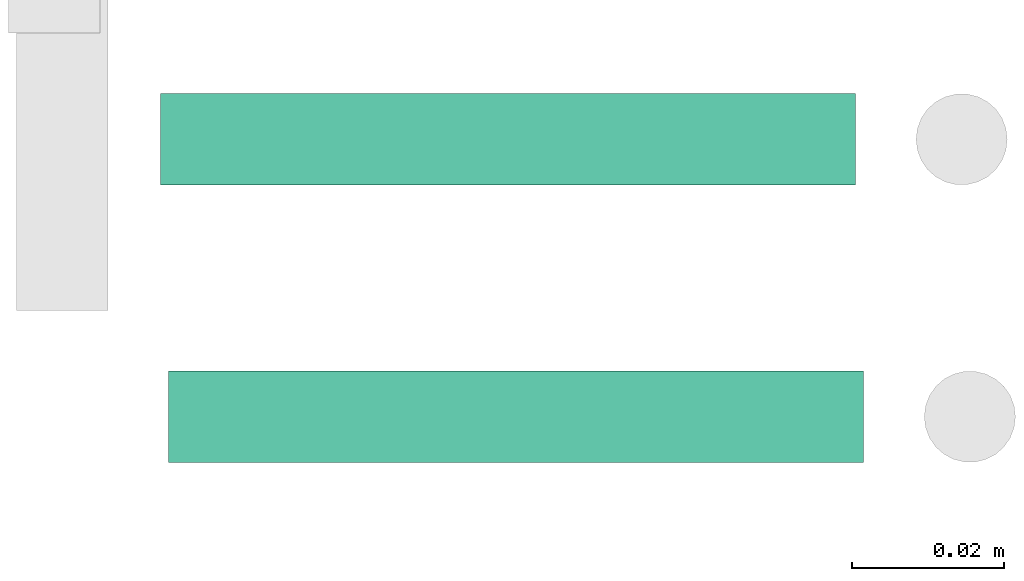
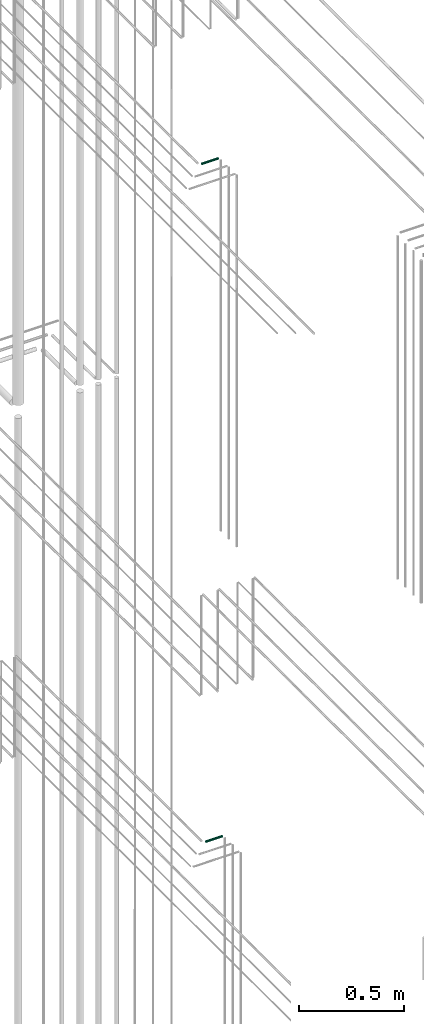
# One storey, part 291 of 331: 2 flow segments.
"""IFC2X3 building model written with IfcOpenShell, lengths in millimetres."""

import ifcopenshell
import ifcopenshell.guid

model = None  # the IFC model being written
_history = None  # IfcOwnerHistory: only IFC2X3 demands one
_inside = {}  # id of a spatial element -> (the spatial element, [elements in it])
_under = {}  # id of a project, library or spatial element -> (it, [spatial elements below it])
_declared = {}  # id of a project -> (the project, [libraries it declares])
_typed = {}  # id of a type object -> (the type object, [elements of that type])
_made_of = {}  # id of a material, layer set ... -> (it, [elements and type objects made of it])


def new_model(schema):
    """Start an empty IFC model of exactly this schema.

    Asked for "IFC4X3", IfcOpenShell would pick the latest addendum, in which some entities
    have other attributes; the version numbers below select the first issue.
    IFC2X3 requires an IfcOwnerHistory on every rooted entity: one is made here for all.
    """
    global model, _history
    if schema == "IFC4X3":
        model = ifcopenshell.file(schema_version=(4, 3, 0, 0))
    else:
        model = ifcopenshell.file(schema=schema)
    _inside.clear()
    _under.clear()
    _declared.clear()
    _typed.clear()
    _made_of.clear()
    _history = None
    if model.schema == "IFC2X3":
        org = make("IfcOrganization", Name="unknown")
        user = make(
            "IfcPersonAndOrganization",
            ThePerson=make("IfcPerson", FamilyName="unknown"),
            TheOrganization=org,
        )
        app = make(
            "IfcApplication",
            ApplicationDeveloper=org,
            Version="unknown",
            ApplicationFullName="unknown",
            ApplicationIdentifier="unknown",
        )
        _history = make(
            "IfcOwnerHistory",
            OwningUser=user,
            OwningApplication=app,
            ChangeAction="ADDED",
            CreationDate=0,
        )
    return model


def make(cls, **values):
    """One entity of the class cls with the attributes given. An attribute that is None is left unset."""
    return model.create_entity(
        cls, **{name: value for name, value in values.items() if value is not None}
    )


def entity(cls, *values):
    """Any entity or typed value of the class cls, its attributes in the order of the schema. None: left unset."""
    e = model.create_entity(cls)
    for i, value in enumerate(values):
        if value is not None:
            e[i] = value
    return e


def rooted(cls, **values):
    """An entity with a GlobalId (a new one), such as an element, a storey or a relation."""
    return make(cls, GlobalId=ifcopenshell.guid.new(), OwnerHistory=_history, **values)


def si_unit(unit_type, name, prefix=None):
    """IfcSIUnit, for example si_unit("LENGTHUNIT", "METRE", prefix="MILLI")."""
    return make("IfcSIUnit", UnitType=unit_type, Prefix=prefix, Name=name)


def converted_unit(unit_type, name, factor, base, dimensions=None, offset=None):
    """IfcConversionBasedUnit, such as the inch: factor (a typed value) times the base unit."""
    return make(
        "IfcConversionBasedUnit"
        if offset is None
        else "IfcConversionBasedUnitWithOffset",
        ConversionOffset=offset,
        Dimensions=None
        if dimensions is None
        else entity("IfcDimensionalExponents", *dimensions),
        UnitType=unit_type,
        Name=name,
        ConversionFactor=make(
            "IfcMeasureWithUnit", ValueComponent=factor, UnitComponent=base
        ),
    )


def derived_unit(unit_type, elements):
    """IfcDerivedUnit: a product of units, each with its exponent."""
    return make(
        "IfcDerivedUnit",
        Elements=[
            make("IfcDerivedUnitElement", Unit=unit, Exponent=power)
            for unit, power in elements
        ],
        UnitType=unit_type,
    )


def assignment(units):
    """IfcUnitAssignment: the units of a project."""
    return None if units is None else make("IfcUnitAssignment", Units=units)


def point(xyz):
    """IfcCartesianPoint."""
    return None if xyz is None else make("IfcCartesianPoint", Coordinates=xyz)


def direction(xyz):
    """IfcDirection."""
    return None if xyz is None else make("IfcDirection", DirectionRatios=xyz)


def frame(location, z_axis=None, x_axis=None):
    """IfcAxis2Placement3D, a coordinate frame: its origin and axes. An axis left out is left unset."""
    return make(
        "IfcAxis2Placement3D",
        Location=point(location),
        Axis=direction(z_axis),
        RefDirection=direction(x_axis),
    )


def frame_2d(location, x_axis=None):
    """IfcAxis2Placement2D, a coordinate frame in the plane: its origin and x axis."""
    return make(
        "IfcAxis2Placement2D", Location=point(location), RefDirection=direction(x_axis)
    )


def origin():
    """The frame at (0, 0, 0) with its axes left unset."""
    return frame((0.0, 0.0, 0.0))


def origin_2d_with_axis():
    """The frame at (0, 0) in the plane with the x axis (1, 0) written out."""
    return frame_2d((0.0, 0.0), x_axis=(1.0, 0.0))


def place(relative_to, where):
    """IfcLocalPlacement: puts the frame where relative to a parent placement (None: the world)."""
    return make(
        "IfcLocalPlacement", PlacementRelTo=relative_to, RelativePlacement=where
    )


def context(
    kind, dimensions, precision=None, world=None, true_north=None, identifier=None
):
    """IfcGeometricRepresentationContext, for example the 3D "Model" context."""
    return make(
        "IfcGeometricRepresentationContext",
        ContextIdentifier=identifier,
        ContextType=kind,
        CoordinateSpaceDimension=dimensions,
        Precision=precision,
        WorldCoordinateSystem=world,
        TrueNorth=true_north,
    )


def subcontext(parent, identifier, kind, view, scale=None):
    """IfcGeometricRepresentationSubContext, for example "Body" below "Model"."""
    return make(
        "IfcGeometricRepresentationSubContext",
        ContextIdentifier=identifier,
        ContextType=kind,
        ParentContext=parent,
        TargetScale=scale,
        TargetView=view,
    )


def project(units=None, contexts=None):
    """IfcProject with its units and contexts."""
    return rooted(
        "IfcProject",
        Name="project",
        RepresentationContexts=contexts,
        UnitsInContext=assignment(units),
    )


def spatial(cls, under=None, at=None, **own):
    """A site, building, storey or space (cls), placed at a placement, below another one or the project."""
    s = rooted(cls, ObjectPlacement=at, **own)
    if under is not None:
        _under.setdefault(under.id(), (under, []))[1].append(s)
    return s


def profile(cls, at=None, kind="AREA", **sizes):
    """A parametric profile (cls). Its sizes go by their IFC names, for example OverallWidth=200.0."""
    return make(cls, ProfileType=kind, Position=at, **sizes)


def circle(**sizes):
    """IfcCircleProfileDef."""
    return profile("IfcCircleProfileDef", **sizes)


def extrude(swept, where, along, depth):
    """IfcExtrudedAreaSolid: the profile swept, set in the frame where, extruded along a direction by depth."""
    return make(
        "IfcExtrudedAreaSolid",
        SweptArea=swept,
        Position=where,
        ExtrudedDirection=direction(along),
        Depth=depth,
    )


def shape(context_of_items, identifier, shape_type, items):
    """IfcShapeRepresentation: the items that make up one representation, for example the "Body"."""
    return make(
        "IfcShapeRepresentation",
        ContextOfItems=context_of_items,
        RepresentationIdentifier=identifier,
        RepresentationType=shape_type,
        Items=items,
    )


def made_of(thing, what):
    """Note that an element or type object is made of a material, layer set ...; save() writes the relation."""
    if what is not None:
        _made_of.setdefault(what.id(), (what, []))[1].append(thing)
    return thing


def type_object(cls, material=None, **own):
    """A type object (cls), such as IfcWallType, which elements share."""
    return made_of(rooted(cls, **own), material)


def element(
    cls,
    number,
    at=None,
    inside=None,
    cuts=None,
    type_object=None,
    material=None,
    context=None,
    identifier="Body",
    shape_type=None,
    held_by="IfcProductDefinitionShape",
    body=None,
    shapes=None,
    **own,
):
    """One element of the class cls, such as IfcWall. Its Tag is "e" and its number.

    at: its placement. inside: the storey or other place that contains it. cuts: it is an
    opening in that element (IfcRelVoidsElement). A single representation is given by context,
    identifier, shape_type and body (its items); several are given by shapes. held_by: the class
    of the entity that holds the representations. save() writes the other relations.
    """
    e = rooted(cls, Tag="e%d" % number, ObjectPlacement=at, **own)
    if body is not None:
        shapes = [shape(context, identifier, shape_type, body)]
    if shapes is not None:
        e.Representation = make(held_by, Representations=shapes)
    if inside is not None:
        _inside.setdefault(inside.id(), (inside, []))[1].append(e)
    if cuts is not None:
        rooted(
            "IfcRelVoidsElement", RelatingBuildingElement=cuts, RelatedOpeningElement=e
        )
    if type_object is not None:
        _typed.setdefault(type_object.id(), (type_object, []))[1].append(e)
    return made_of(e, material)


def aggregate(whole, parts):
    """IfcRelAggregates: a whole, such as a stair, and the parts it consists of."""
    return rooted("IfcRelAggregates", RelatingObject=whole, RelatedObjects=parts)


def save(model, path):
    """Write the relations noted so far, then the file.

    IfcRelAggregates (storeys below a building ...), IfcRelContainedInSpatialStructure (elements
    in a storey), IfcRelDefinesByType, IfcRelAssociatesMaterial and IfcRelDeclares: one each for
    every whole, place, type object, material and project.
    """
    for whole, parts in _under.values():
        aggregate(whole, parts)
    for where, things in _inside.values():
        rooted(
            "IfcRelContainedInSpatialStructure",
            RelatedElements=things,
            RelatingStructure=where,
        )
    for kind, things in _typed.values():
        rooted("IfcRelDefinesByType", RelatedObjects=things, RelatingType=kind)
    for what, things in _made_of.values():
        rooted("IfcRelAssociatesMaterial", RelatedObjects=things, RelatingMaterial=what)
    for by, libraries in _declared.values():
        rooted("IfcRelDeclares", RelatingContext=by, RelatedDefinitions=libraries)
    model.write(path)


model = new_model("IFC2X3")

# Units and contexts
model_context = context("Model", 3, precision=0.01, world=origin(), true_north=direction((6.12303176911189e-17, 1.0)))
body_context = subcontext(model_context, "Body", "Model", "MODEL_VIEW")
ifc_project = project(units=[si_unit("LENGTHUNIT", "METRE", prefix="MILLI"), si_unit("AREAUNIT", "SQUARE_METRE"), si_unit("VOLUMEUNIT", "CUBIC_METRE"), converted_unit("PLANEANGLEUNIT", "DEGREE", entity("IfcRatioMeasure", 0.0174532925199433), si_unit("PLANEANGLEUNIT", "RADIAN"), dimensions=[0, 0, 0, 0, 0, 0, 0]), si_unit("MASSUNIT", "GRAM", prefix="KILO"), derived_unit("MASSDENSITYUNIT", [(si_unit("MASSUNIT", "GRAM", prefix="KILO"), 1), (si_unit("LENGTHUNIT", "METRE"), -3)]), derived_unit("MOMENTOFINERTIAUNIT", [(si_unit("LENGTHUNIT", "METRE"), 4)]), si_unit("TIMEUNIT", "SECOND"), si_unit("FREQUENCYUNIT", "HERTZ"), si_unit("THERMODYNAMICTEMPERATUREUNIT", "DEGREE_CELSIUS"), derived_unit("THERMALTRANSMITTANCEUNIT", [(si_unit("MASSUNIT", "GRAM", prefix="KILO"), 1), (si_unit("THERMODYNAMICTEMPERATUREUNIT", "KELVIN"), -1), (si_unit("TIMEUNIT", "SECOND"), -3)]), derived_unit("VOLUMETRICFLOWRATEUNIT", [(si_unit("LENGTHUNIT", "METRE"), 3), (si_unit("TIMEUNIT", "SECOND"), -1)]), derived_unit("MASSFLOWRATEUNIT", [(si_unit("MASSUNIT", "GRAM", prefix="KILO"), 1), (si_unit("TIMEUNIT", "SECOND"), -1)]), derived_unit("ROTATIONALFREQUENCYUNIT", [(si_unit("TIMEUNIT", "SECOND"), -1)]), si_unit("ELECTRICCURRENTUNIT", "AMPERE"), si_unit("ELECTRICVOLTAGEUNIT", "VOLT"), si_unit("POWERUNIT", "WATT"), si_unit("FORCEUNIT", "NEWTON", prefix="KILO"), si_unit("ILLUMINANCEUNIT", "LUX"), si_unit("LUMINOUSFLUXUNIT", "LUMEN"), si_unit("LUMINOUSINTENSITYUNIT", "CANDELA"), derived_unit("USERDEFINED", [(si_unit("MASSUNIT", "GRAM", prefix="KILO"), -1), (si_unit("LENGTHUNIT", "METRE"), -2), (si_unit("TIMEUNIT", "SECOND"), 3), (si_unit("LUMINOUSFLUXUNIT", "LUMEN"), 1)]), derived_unit("LINEARVELOCITYUNIT", [(si_unit("LENGTHUNIT", "METRE"), 1), (si_unit("TIMEUNIT", "SECOND"), -1)]), si_unit("PRESSUREUNIT", "PASCAL"), derived_unit("USERDEFINED", [(si_unit("LENGTHUNIT", "METRE"), -2), (si_unit("MASSUNIT", "GRAM", prefix="KILO"), 1), (si_unit("TIMEUNIT", "SECOND"), -2)]), derived_unit("LINEARFORCEUNIT", [(si_unit("MASSUNIT", "GRAM", prefix="KILO"), 1), (si_unit("LENGTHUNIT", "METRE"), 1), (si_unit("TIMEUNIT", "SECOND"), -2), (si_unit("LENGTHUNIT", "METRE"), -1)]), derived_unit("PLANARFORCEUNIT", [(si_unit("MASSUNIT", "GRAM", prefix="KILO"), 1), (si_unit("LENGTHUNIT", "METRE"), 1), (si_unit("TIMEUNIT", "SECOND"), -2), (si_unit("LENGTHUNIT", "METRE"), -2)])], contexts=[model_context])

# Site, building, storey
site_placement = place(None, frame((0.0, -0.00077364408347762, 0.0)))
site = spatial("IfcSite", under=ifc_project, at=site_placement, CompositionType="ELEMENT")
building_placement = place(site_placement, origin())
building = spatial("IfcBuilding", under=site, at=building_placement, CompositionType="ELEMENT")
storey_placement = place(building_placement, origin())
storey = spatial("IfcBuildingStorey", under=building, at=storey_placement, CompositionType="ELEMENT", Elevation=0.0)

# Flow segments
pipe_segment_type = type_object("IfcPipeSegmentType", PredefinedType="NOTDEFINED")
flow_segment_1_placement = place(storey_placement, frame((62260.1177906274, 3847.40472776424, 15142.4047277641)))
element("IfcFlowSegment", 1, at=flow_segment_1_placement, inside=storey, type_object=pipe_segment_type, context=body_context, shape_type="SweptSolid", body=[
    extrude(circle(Radius=6.0, at=frame_2d((0.0, -2.16573425859679e-12), x_axis=(1.0, 0.0))), frame((0.0, 7.59527223591562, 7.59527223591454), z_axis=(1.0, 0.0, 0.0), x_axis=(0.0, -1.0, 0.0)), (0.0, 0.0, 1.0), 91.3842064197939),
])
flow_segment_2_placement = place(storey_placement, frame((62259.0420767625, 3883.89349484372, 19042.4047277641)))
element("IfcFlowSegment", 2, at=flow_segment_2_placement, inside=storey, type_object=pipe_segment_type, context=body_context, shape_type="SweptSolid", body=[
    extrude(circle(Radius=6.0, at=origin_2d_with_axis()), frame((0.0, 7.59527223591562, 7.5952722359167), z_axis=(1.0, 0.0, 0.0), x_axis=(0.0, -1.0, 0.0)), (0.0, 0.0, 1.0), 91.3842064197939),
])

save(model, "model.ifc")
